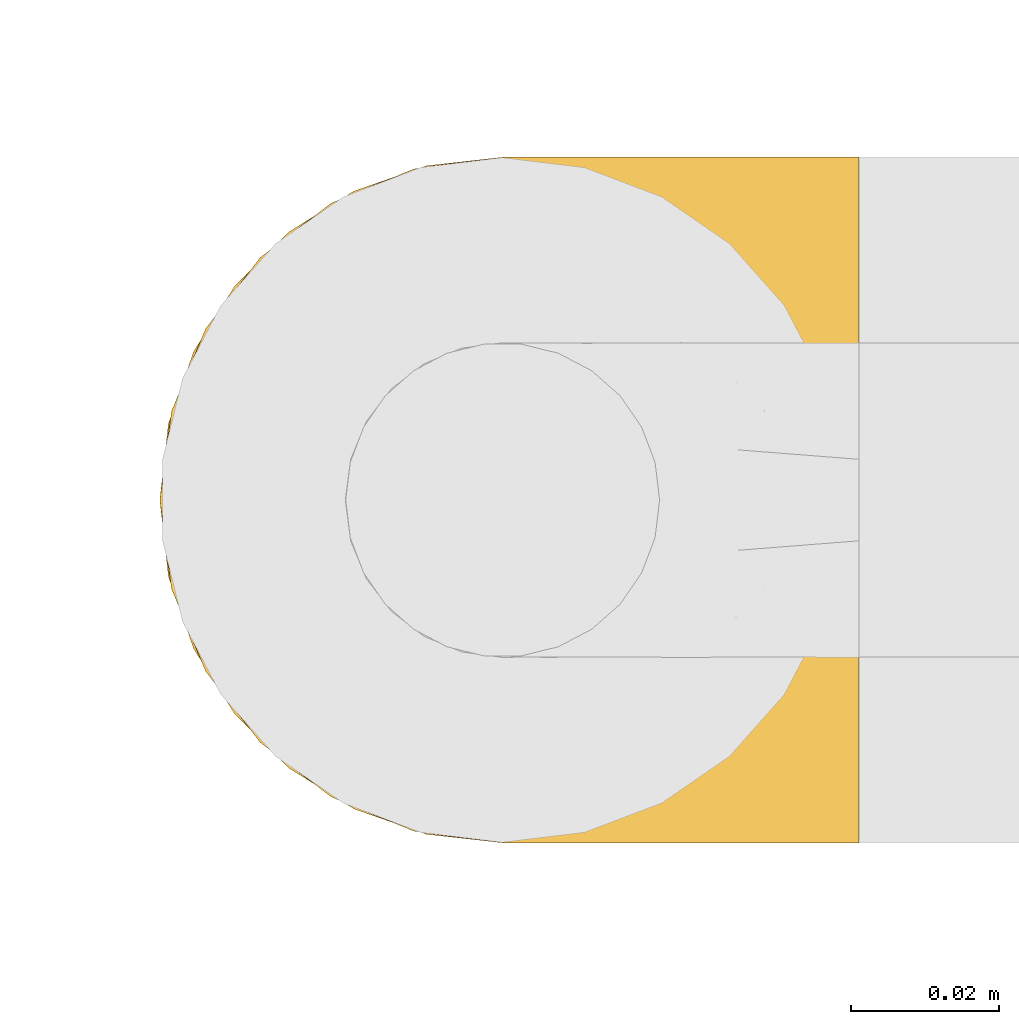
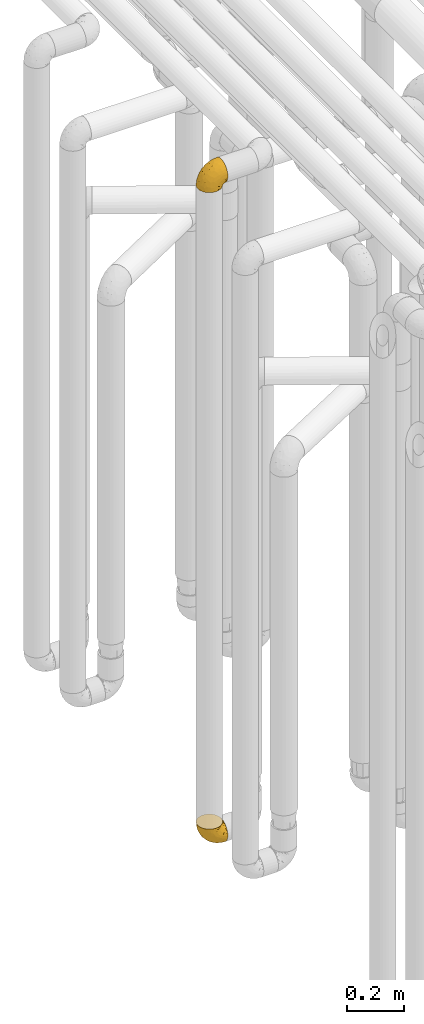
# One storey, part 163 of 827: 2 coverings.
"""IFC2X3 building model written with IfcOpenShell, lengths in millimetres."""

from ifc_helpers import new_model, entity, si_unit, converted_unit, derived_unit, direction, frame, origin, place, context, subcontext, project, spatial, faceted_brep, element, save


model = new_model("IFC2X3")

# Units and contexts
model_context = context("Model", 3, precision=0.01, world=origin(), true_north=direction((6.12303176911189e-17, 1.0)))
body_context = subcontext(model_context, "Body", "Model", "MODEL_VIEW")
ifc_project = project(units=[si_unit("LENGTHUNIT", "METRE", prefix="MILLI"), si_unit("AREAUNIT", "SQUARE_METRE"), si_unit("VOLUMEUNIT", "CUBIC_METRE"), converted_unit("PLANEANGLEUNIT", "DEGREE", entity("IfcRatioMeasure", 0.0174532925199433), si_unit("PLANEANGLEUNIT", "RADIAN"), dimensions=[0, 0, 0, 0, 0, 0, 0]), si_unit("MASSUNIT", "GRAM", prefix="KILO"), derived_unit("MASSDENSITYUNIT", [(si_unit("MASSUNIT", "GRAM", prefix="KILO"), 1), (si_unit("LENGTHUNIT", "METRE"), -3)]), derived_unit("MOMENTOFINERTIAUNIT", [(si_unit("LENGTHUNIT", "METRE"), 4)]), si_unit("TIMEUNIT", "SECOND"), si_unit("FREQUENCYUNIT", "HERTZ"), si_unit("THERMODYNAMICTEMPERATUREUNIT", "DEGREE_CELSIUS"), derived_unit("THERMALTRANSMITTANCEUNIT", [(si_unit("MASSUNIT", "GRAM", prefix="KILO"), 1), (si_unit("THERMODYNAMICTEMPERATUREUNIT", "KELVIN"), -1), (si_unit("TIMEUNIT", "SECOND"), -3)]), derived_unit("VOLUMETRICFLOWRATEUNIT", [(si_unit("LENGTHUNIT", "METRE"), 3), (si_unit("TIMEUNIT", "SECOND"), -1)]), derived_unit("MASSFLOWRATEUNIT", [(si_unit("MASSUNIT", "GRAM", prefix="KILO"), 1), (si_unit("TIMEUNIT", "SECOND"), -1)]), derived_unit("ROTATIONALFREQUENCYUNIT", [(si_unit("TIMEUNIT", "SECOND"), -1)]), si_unit("ELECTRICCURRENTUNIT", "AMPERE"), si_unit("ELECTRICVOLTAGEUNIT", "VOLT"), si_unit("POWERUNIT", "WATT"), si_unit("FORCEUNIT", "NEWTON", prefix="KILO"), si_unit("ILLUMINANCEUNIT", "LUX"), si_unit("LUMINOUSFLUXUNIT", "LUMEN"), si_unit("LUMINOUSINTENSITYUNIT", "CANDELA"), derived_unit("USERDEFINED", [(si_unit("MASSUNIT", "GRAM", prefix="KILO"), -1), (si_unit("LENGTHUNIT", "METRE"), -2), (si_unit("TIMEUNIT", "SECOND"), 3), (si_unit("LUMINOUSFLUXUNIT", "LUMEN"), 1)]), derived_unit("LINEARVELOCITYUNIT", [(si_unit("LENGTHUNIT", "METRE"), 1), (si_unit("TIMEUNIT", "SECOND"), -1)]), si_unit("PRESSUREUNIT", "PASCAL"), derived_unit("USERDEFINED", [(si_unit("LENGTHUNIT", "METRE"), -2), (si_unit("MASSUNIT", "GRAM", prefix="KILO"), 1), (si_unit("TIMEUNIT", "SECOND"), -2)]), derived_unit("LINEARFORCEUNIT", [(si_unit("MASSUNIT", "GRAM", prefix="KILO"), 1), (si_unit("LENGTHUNIT", "METRE"), 1), (si_unit("TIMEUNIT", "SECOND"), -2), (si_unit("LENGTHUNIT", "METRE"), -1)]), derived_unit("PLANARFORCEUNIT", [(si_unit("MASSUNIT", "GRAM", prefix="KILO"), 1), (si_unit("LENGTHUNIT", "METRE"), 1), (si_unit("TIMEUNIT", "SECOND"), -2), (si_unit("LENGTHUNIT", "METRE"), -2)])], contexts=[model_context])

# Site, building, storey
site_placement = place(None, origin())
site = spatial("IfcSite", under=ifc_project, at=site_placement, CompositionType="ELEMENT")
building_placement = place(site_placement, origin())
building = spatial("IfcBuilding", under=site, at=building_placement, CompositionType="ELEMENT")
storey_placement = place(building_placement, frame((0.0, 0.0, 28200.0)))
storey = spatial("IfcBuildingStorey", under=building, at=storey_placement, Name="08", CompositionType="ELEMENT", Elevation=28200.0)

# Coverings
covering_1_placement = place(storey_placement, frame((35072.24, 11758.41, 352.2)))
element("IfcCovering", 1, at=covering_1_placement, inside=storey, Name=":ADSK_", ObjectType=":ADSK_", PredefinedType="INSULATION", context=body_context, shape_type="Brep", body=[
    faceted_brep([(18.98, 83.91, 95.8), (11.67, 76.59, 95.8), (6.17, 67.83, 95.8), (2.75, 58.07, 95.8), (1.6, 47.8, 95.8), (2.75, 37.51, 95.8), (6.17, 27.74, 95.8), (11.68, 18.98, 95.8), (19.0, 11.67, 95.8), (27.76, 6.17, 95.8), (37.52, 2.75, 95.8), (47.8, 1.6, 95.8), (51.94, 2.06, 95.8), (55.01, 2.41, 95.8), (58.08, 2.75, 95.8), (62.96, 4.46, 95.8), (67.85, 6.17, 95.8), (72.23, 8.93, 95.8), (76.61, 11.68, 95.8), (80.26, 15.34, 95.8), (83.92, 19.0, 95.8), (89.42, 27.76, 95.8), (91.13, 32.64, 95.8), (92.84, 37.52, 95.8), (94.0, 47.8, 95.8), (92.84, 58.08, 95.8), (91.13, 62.96, 95.8), (89.42, 67.85, 95.8), (83.91, 76.61, 95.8), (80.25, 80.26, 95.8), (76.59, 83.92, 95.8), (72.21, 86.67, 95.8), (67.83, 89.42, 95.8), (62.95, 91.13, 95.8), (58.07, 92.84, 95.8), (55.0, 93.18, 95.8), (51.94, 93.53, 95.8), (47.8, 94.0, 95.8), (37.51, 92.84, 95.8), (27.74, 89.42, 95.8), (95.8, 47.8, 94.0), (95.8, 35.84, 92.42), (95.8, 24.7, 87.81), (95.8, 19.91, 84.13), (95.8, 15.13, 80.46), (95.8, 11.46, 75.68), (95.8, 7.78, 70.9), (95.8, 5.48, 65.32), (95.8, 3.17, 59.75), (95.8, 2.69, 56.14), (95.8, 2.42, 54.06), (95.8, 2.14, 51.97), (95.8, 1.6, 47.8), (95.8, 3.17, 35.84), (95.8, 7.78, 24.7), (95.8, 15.13, 15.13), (95.8, 24.7, 7.78), (95.8, 35.84, 3.17), (95.8, 47.8, 1.6), (95.8, 59.75, 3.17), (95.8, 70.9, 7.78), (95.8, 80.46, 15.13), (95.8, 87.81, 24.7), (95.8, 92.42, 35.84), (95.8, 94.0, 47.8), (95.8, 93.45, 51.97), (95.8, 92.9, 56.14), (95.8, 92.42, 59.75), (95.8, 90.11, 65.32), (95.8, 87.81, 70.9), (95.8, 84.13, 75.68), (95.8, 80.46, 80.46), (95.8, 75.68, 84.13), (95.8, 70.9, 87.81), (95.8, 59.75, 92.42), (60.58, 71.98, 15.84), (74.11, 63.6, 6.99), (51.59, 59.72, 14.39), (66.69, 47.8, 6.21), (76.19, 55.16, 4.26), (84.43, 47.8, 3.39), (31.2, 63.76, 31.2), (42.88, 72.22, 26.47), (79.41, 74.18, 11.44), (60.7, 92.52, 47.66), (61.85, 94.0, 61.85), (65.75, 94.0, 59.25), (69.64, 94.0, 56.65), (73.53, 94.0, 54.05), (77.43, 94.0, 51.45), (74.59, 82.14, 19.8), (54.72, 80.34, 26.22), (64.18, 87.52, 31.58), (37.94, 79.59, 38.36), (25.89, 78.25, 51.54), (34.73, 85.01, 51.6), (42.89, 90.25, 55.97), (49.83, 93.2, 62.88), (48.58, 87.23, 41.35), (22.41, 85.55, 82.24), (78.69, 93.0, 40.88), (81.64, 89.31, 29.0), (6.22, 61.31, 74.06), (12.11, 56.86, 54.53), (14.81, 68.34, 57.98), (21.61, 65.71, 43.81), (22.41, 56.99, 38.22), (30.12, 72.15, 38.33), (10.01, 70.34, 74.76), (15.36, 78.36, 76.85), (3.39, 47.8, 84.43), (19.59, 47.8, 40.43), (30.01, 47.8, 30.01), (41.19, 93.06, 78.67), (48.54, 94.0, 92.06), (49.28, 94.0, 88.32), (49.82, 94.0, 85.6), (50.37, 94.0, 82.88), (50.91, 94.0, 80.15), (51.45, 94.0, 77.43), (31.61, 89.88, 76.36), (80.15, 94.0, 50.91), (82.88, 94.0, 50.37), (85.6, 94.0, 49.82), (88.32, 94.0, 49.28), (90.19, 94.0, 48.91), (92.06, 94.0, 48.54), (6.21, 47.8, 66.69), (54.05, 94.0, 73.53), (56.65, 94.0, 69.64), (59.25, 94.0, 65.75), (24.66, 83.7, 66.13), (40.43, 47.8, 19.59), (35.17, 55.9, 24.64), (12.9, 47.8, 53.56), (53.56, 47.8, 12.9), (85.34, 81.75, 82.81), (78.44, 86.43, 81.22), (84.37, 79.8, 86.57), (89.05, 69.84, 92.75), (82.76, 79.5, 89.68), (86.31, 88.08, 72.26), (83.73, 91.6, 64.73), (77.31, 92.93, 62.45), (87.78, 92.43, 60.63), (87.91, 93.24, 56.91), (81.29, 93.36, 58.14), (93.97, 57.25, 93.7), (70.76, 89.41, 83.4), (63.67, 92.89, 75.54), (62.62, 92.66, 79.46), (90.64, 79.58, 82.28), (84.08, 86.51, 76.25), (76.28, 86.29, 84.69), (77.45, 83.91, 90.18), (88.72, 90.94, 65.12), (71.28, 91.94, 71.71), (68.09, 91.98, 75.21), (91.07, 82.79, 78.6), (57.47, 93.16, 87.27), (70.34, 88.76, 87.92), (91.35, 73.94, 86.94), (62.99, 91.89, 86.1), (94.52, 47.8, 94.52), (76.47, 92.22, 66.23), (69.96, 88.56, 91.08), (89.86, 87.72, 71.77), (78.94, 88.33, 76.21), (73.51, 92.18, 68.59), (89.62, 71.78, 89.94), (84.09, 9.09, 76.25), (86.3, 7.51, 72.26), (91.06, 12.8, 78.6), (88.32, 1.6, 49.28), (92.06, 1.6, 48.54), (82.88, 1.6, 50.37), (85.6, 1.6, 49.82), (93.97, 38.35, 93.7), (89.63, 23.84, 89.95), (50.37, 1.6, 82.88), (49.82, 1.6, 85.6), (48.54, 1.6, 92.06), (49.28, 1.6, 88.32), (82.77, 16.1, 89.68), (70.36, 6.84, 87.92), (77.31, 2.66, 62.45), (76.47, 3.37, 66.24), (69.64, 1.6, 56.65), (65.75, 1.6, 59.25), (87.78, 3.16, 60.63), (87.91, 2.35, 56.91), (89.06, 25.77, 92.76), (90.65, 16.02, 82.28), (85.35, 13.85, 82.81), (73.53, 1.6, 54.05), (77.43, 1.6, 51.45), (81.29, 2.23, 58.14), (77.46, 11.69, 90.18), (76.29, 9.31, 84.7), (57.47, 2.43, 87.25), (63.71, 2.71, 75.58), (68.11, 3.61, 75.2), (70.77, 6.18, 83.39), (71.31, 3.66, 71.7), (78.46, 9.17, 81.22), (69.52, 6.77, 90.73), (62.64, 2.93, 79.47), (91.35, 21.66, 86.94), (59.25, 1.6, 65.75), (84.6, 16.09, 86.75), (62.98, 3.7, 86.08), (51.45, 1.6, 77.43), (54.05, 1.6, 73.53), (56.65, 1.6, 69.64), (83.73, 3.99, 64.73), (80.15, 1.6, 50.91), (88.72, 4.65, 65.12), (61.85, 1.6, 61.85), (73.56, 3.43, 68.62), (78.96, 7.27, 76.22), (91.36, 9.46, 74.03), (50.91, 1.6, 80.15), (62.87, 2.4, 49.81), (76.19, 40.43, 4.26), (73.57, 13.57, 19.95), (56.07, 11.3, 30.61), (49.77, 18.65, 25.71), (44.73, 27.26, 22.43), (60.58, 23.61, 15.85), (47.64, 3.07, 60.69), (78.32, 2.69, 40.49), (51.59, 35.87, 14.39), (74.11, 31.99, 6.99), (76.04, 6.71, 29.56), (79.41, 21.41, 11.45), (14.82, 27.24, 57.98), (6.22, 34.26, 74.06), (12.12, 38.73, 54.52), (23.51, 26.97, 43.47), (31.2, 31.83, 31.2), (34.96, 23.4, 33.27), (33.86, 6.91, 64.26), (38.94, 3.4, 74.29), (30.23, 5.84, 80.41), (35.17, 39.69, 24.64), (15.85, 17.6, 73.62), (22.59, 10.38, 78.98), (21.56, 20.6, 53.69), (55.94, 5.36, 42.86), (20.67, 35.73, 41.67), (9.19, 24.84, 79.66), (25.79, 13.87, 58.41), (41.16, 9.06, 47.11), (37.95, 15.99, 38.37)], [[[0, 1, 2, 3, 4, 5, 6, 7, 8, 9, 10, 11, 12, 13, 14, 15, 16, 17, 18, 19, 20, 21, 22, 23, 24, 25, 26, 27, 28, 29, 30, 31, 32, 33, 34, 35, 36, 37, 38, 39]], [[40, 41, 42, 43, 44, 45, 46, 47, 48, 49, 50, 51, 52, 53, 54, 55, 56, 57, 58, 59, 60, 61, 62, 63, 64, 65, 66, 67, 68, 69, 70, 71, 72, 73, 74]], [[75, 76, 77]], [[78, 79, 80]], [[77, 81, 82]], [[76, 75, 83]], [[84, 85, 86, 87, 88, 89]], [[90, 91, 92]], [[76, 60, 59]], [[93, 94, 95]], [[90, 62, 61]], [[83, 61, 60]], [[96, 97, 84]], [[98, 93, 95]], [[0, 39, 99]], [[100, 84, 89]], [[62, 101, 63]], [[2, 102, 3]], [[92, 84, 100]], [[103, 102, 104]], [[103, 105, 106]], [[93, 107, 94]], [[1, 108, 2]], [[92, 101, 90]], [[108, 1, 109]], [[102, 110, 3]], [[93, 82, 107]], [[102, 108, 104]], [[111, 106, 112]], [[109, 0, 99]], [[113, 37, 114, 115, 116, 117, 118, 119]], [[120, 38, 113]], [[100, 89, 121, 122, 123, 124, 125, 126, 64]], [[127, 102, 103]], [[97, 119, 128, 129, 130, 85]], [[99, 120, 131]], [[132, 133, 77]], [[59, 80, 79]], [[1, 0, 109]], [[98, 84, 92]], [[94, 109, 131]], [[120, 39, 38]], [[93, 91, 82]], [[104, 94, 105]], [[97, 113, 119]], [[95, 120, 96]], [[83, 90, 61]], [[91, 93, 98]], [[64, 63, 100]], [[100, 63, 101]], [[77, 76, 79]], [[133, 106, 81]], [[84, 97, 85]], [[113, 96, 120]], [[113, 97, 96]], [[37, 113, 38]], [[110, 102, 127]], [[110, 4, 3]], [[103, 111, 134, 127]], [[90, 75, 91]], [[82, 81, 107]], [[91, 75, 82]], [[77, 82, 75]], [[76, 83, 60]], [[90, 83, 75]], [[105, 107, 81]], [[94, 131, 95]], [[105, 94, 107]], [[109, 94, 104]], [[120, 95, 131]], [[98, 95, 96]], [[84, 98, 96]], [[98, 92, 91]], [[106, 105, 81]], [[103, 104, 105]], [[112, 106, 133]], [[103, 106, 111]], [[112, 133, 132]], [[81, 77, 133]], [[77, 78, 135, 132]], [[120, 99, 39]], [[109, 99, 131]], [[59, 58, 80]], [[59, 79, 76]], [[90, 101, 62]], [[100, 101, 92]], [[2, 108, 102]], [[109, 104, 108]], [[78, 77, 79]], [[136, 137, 138]], [[27, 139, 140]], [[141, 142, 143]], [[144, 145, 121]], [[146, 89, 88]], [[147, 139, 25]], [[148, 149, 150]], [[136, 151, 152]], [[147, 40, 74]], [[24, 147, 25]], [[140, 153, 154]], [[33, 116, 34]], [[73, 72, 151]], [[114, 37, 36, 35, 34, 116, 115]], [[146, 155, 144]], [[156, 85, 130]], [[157, 149, 148]], [[151, 158, 152]], [[117, 33, 159]], [[29, 154, 160]], [[161, 74, 73]], [[162, 128, 119]], [[66, 65, 64, 126, 125, 124, 123, 122, 67]], [[163, 147, 24]], [[27, 140, 28]], [[149, 129, 150]], [[139, 27, 26, 25]], [[68, 144, 69]], [[129, 128, 150]], [[164, 87, 86]], [[130, 129, 149]], [[122, 145, 67]], [[154, 153, 148]], [[162, 119, 159]], [[165, 30, 160]], [[150, 160, 148]], [[128, 162, 150]], [[30, 165, 31]], [[145, 144, 68]], [[89, 146, 144]], [[87, 164, 143]], [[166, 155, 142]], [[88, 87, 143]], [[162, 160, 150]], [[160, 30, 29]], [[154, 29, 28]], [[140, 154, 28]], [[160, 154, 148]], [[140, 137, 153]], [[157, 148, 153]], [[156, 130, 157]], [[153, 137, 157]], [[157, 137, 156]], [[167, 137, 136]], [[168, 85, 156]], [[152, 168, 167]], [[167, 168, 156]], [[164, 152, 141]], [[71, 158, 72]], [[152, 167, 136]], [[88, 142, 146]], [[144, 155, 69]], [[146, 142, 155]], [[70, 166, 71]], [[142, 141, 166]], [[70, 69, 155]], [[141, 158, 71]], [[161, 73, 151]], [[138, 137, 140]], [[161, 136, 169]], [[136, 161, 151]], [[74, 161, 169]], [[152, 158, 141]], [[151, 72, 158]], [[168, 152, 164]], [[137, 167, 156]], [[164, 86, 168]], [[85, 168, 86]], [[116, 33, 117]], [[130, 149, 157]], [[67, 145, 68]], [[121, 89, 144]], [[145, 122, 121]], [[40, 147, 163]], [[169, 147, 74]], [[159, 33, 32]], [[162, 159, 32]], [[159, 119, 118, 117]], [[139, 147, 169]], [[139, 169, 138]], [[162, 32, 31]], [[141, 143, 164]], [[88, 143, 142]], [[71, 166, 141]], [[155, 166, 70]], [[139, 138, 140]], [[169, 136, 138]], [[160, 162, 165]], [[162, 31, 165]], [[170, 171, 172]], [[173, 174, 52, 51, 50, 49, 48, 175, 176]], [[177, 178, 41]], [[179, 15, 180]], [[12, 11, 181, 182, 180, 14, 13]], [[183, 21, 20]], [[19, 18, 184]], [[185, 186, 187]], [[186, 188, 187]], [[43, 172, 44]], [[189, 190, 47]], [[23, 22, 21, 191]], [[170, 192, 193]], [[40, 163, 177]], [[194, 195, 196]], [[24, 23, 177]], [[197, 198, 183]], [[199, 15, 179]], [[47, 46, 189]], [[200, 201, 202]], [[201, 203, 204]], [[205, 206, 184]], [[207, 41, 178]], [[16, 15, 199]], [[14, 180, 15]], [[202, 201, 198]], [[208, 201, 200]], [[163, 24, 177]], [[48, 47, 190]], [[196, 195, 189]], [[197, 184, 202]], [[204, 193, 209]], [[210, 211, 212]], [[206, 212, 213]], [[205, 17, 210]], [[184, 206, 202]], [[210, 212, 206]], [[185, 194, 214]], [[189, 215, 190]], [[216, 45, 214]], [[186, 171, 170]], [[189, 216, 196]], [[197, 20, 19]], [[194, 185, 187]], [[197, 183, 20]], [[184, 197, 19]], [[197, 202, 198]], [[206, 200, 202]], [[204, 183, 198]], [[201, 208, 203]], [[203, 208, 217]], [[204, 198, 201]], [[217, 188, 218]], [[193, 219, 170]], [[171, 186, 185]], [[170, 218, 186]], [[170, 219, 218]], [[42, 207, 192]], [[171, 220, 172]], [[216, 189, 46]], [[214, 194, 196]], [[44, 220, 45]], [[214, 196, 216]], [[216, 46, 45]], [[214, 45, 220]], [[192, 43, 42]], [[204, 203, 219]], [[207, 193, 192]], [[209, 193, 178]], [[41, 207, 42]], [[193, 207, 178]], [[43, 192, 172]], [[170, 172, 192]], [[204, 219, 193]], [[219, 203, 218]], [[217, 218, 203]], [[188, 186, 218]], [[206, 213, 200]], [[208, 200, 213]], [[199, 210, 16]], [[215, 189, 195]], [[215, 175, 190]], [[175, 48, 190]], [[199, 179, 221, 211]], [[210, 199, 211]], [[23, 191, 177]], [[40, 177, 41]], [[178, 177, 191]], [[21, 183, 191]], [[209, 191, 183]], [[205, 18, 17]], [[17, 16, 210]], [[171, 185, 214]], [[172, 220, 44]], [[214, 220, 171]], [[191, 209, 178]], [[204, 209, 183]], [[206, 205, 210]], [[18, 205, 184]], [[222, 195, 194, 187, 188, 217]], [[57, 223, 80]], [[224, 225, 226]], [[226, 227, 228]], [[229, 217, 208, 213, 212, 211]], [[230, 52, 174, 173, 176, 175, 215, 195]], [[231, 232, 228]], [[231, 78, 223]], [[223, 57, 232]], [[224, 233, 225]], [[233, 54, 53]], [[234, 232, 56]], [[56, 55, 234]], [[234, 224, 228]], [[235, 236, 237]], [[224, 55, 54]], [[238, 239, 240]], [[52, 230, 53]], [[241, 242, 243]], [[227, 244, 231]], [[11, 10, 242]], [[236, 6, 5]], [[7, 245, 8]], [[8, 246, 9]], [[238, 247, 235]], [[222, 229, 248]], [[242, 211, 221, 179, 180, 182, 181, 11]], [[233, 53, 230]], [[111, 112, 249]], [[250, 6, 236]], [[246, 251, 241]], [[6, 250, 7]], [[127, 236, 110]], [[248, 229, 252]], [[246, 8, 245]], [[235, 245, 250]], [[236, 5, 110]], [[235, 249, 238]], [[237, 236, 127]], [[243, 9, 246]], [[252, 229, 241]], [[56, 232, 57]], [[222, 230, 195]], [[225, 248, 252]], [[248, 233, 230]], [[54, 233, 224]], [[231, 228, 227]], [[244, 132, 231]], [[248, 225, 233]], [[226, 225, 253]], [[235, 250, 236]], [[245, 7, 250]], [[251, 246, 245]], [[243, 246, 241]], [[247, 245, 235]], [[252, 251, 253]], [[229, 222, 217]], [[230, 222, 248]], [[5, 4, 110]], [[237, 127, 134, 111]], [[238, 249, 239]], [[224, 234, 55]], [[232, 234, 228]], [[242, 241, 229]], [[10, 9, 243]], [[211, 242, 229]], [[10, 243, 242]], [[80, 223, 78]], [[80, 58, 57]], [[231, 223, 232]], [[227, 240, 239]], [[224, 226, 228]], [[240, 226, 253]], [[227, 239, 244]], [[226, 240, 227]], [[251, 247, 253]], [[240, 253, 247]], [[249, 235, 237]], [[237, 111, 249]], [[112, 132, 244]], [[112, 244, 249]], [[78, 231, 132, 135]], [[249, 244, 239]], [[247, 238, 240]], [[245, 247, 251]], [[251, 252, 241]], [[225, 252, 253]]]),
])
covering_2_placement = place(storey_placement, frame((35072.24, 11758.41, 3150.4)))
element("IfcCovering", 2, at=covering_2_placement, inside=storey, Name=":ADSK_", ObjectType=":ADSK_", PredefinedType="INSULATION", context=body_context, shape_type="Brep", body=[
    faceted_brep([(95.8, 83.91, 78.41), (95.8, 76.59, 85.72), (95.8, 67.83, 91.22), (95.8, 58.07, 94.64), (95.8, 47.8, 95.8), (95.8, 37.51, 94.64), (95.8, 27.74, 91.22), (95.8, 18.98, 85.71), (95.8, 11.67, 78.39), (95.8, 6.17, 69.63), (95.8, 2.75, 59.87), (95.8, 1.6, 49.6), (95.8, 2.06, 45.45), (95.8, 2.41, 42.38), (95.8, 2.75, 39.31), (95.8, 4.46, 34.43), (95.8, 6.17, 29.54), (95.8, 8.93, 25.16), (95.8, 11.68, 20.78), (95.8, 15.34, 17.13), (95.8, 19.0, 13.47), (95.8, 27.76, 7.97), (95.8, 32.64, 6.26), (95.8, 37.52, 4.55), (95.8, 47.8, 3.4), (95.8, 58.08, 4.55), (95.8, 62.96, 6.26), (95.8, 67.85, 7.97), (95.8, 76.61, 13.48), (95.8, 80.26, 17.14), (95.8, 83.92, 20.8), (95.8, 86.67, 25.18), (95.8, 89.42, 29.56), (95.8, 91.13, 34.44), (95.8, 92.84, 39.32), (95.8, 93.18, 42.39), (95.8, 93.53, 45.45), (95.8, 94.0, 49.6), (95.8, 92.84, 59.88), (95.8, 89.42, 69.65), (94.0, 47.8, 1.6), (92.42, 35.84, 1.6), (87.81, 24.7, 1.6), (84.13, 19.91, 1.6), (80.46, 15.13, 1.6), (75.68, 11.46, 1.6), (70.9, 7.78, 1.6), (65.32, 5.48, 1.6), (59.75, 3.17, 1.6), (56.14, 2.69, 1.6), (54.06, 2.42, 1.6), (51.97, 2.14, 1.6), (47.8, 1.6, 1.6), (35.84, 3.17, 1.6), (24.7, 7.78, 1.6), (15.13, 15.13, 1.6), (7.78, 24.7, 1.6), (3.17, 35.84, 1.6), (1.6, 47.8, 1.6), (3.17, 59.75, 1.6), (7.78, 70.9, 1.6), (15.13, 80.46, 1.6), (24.7, 87.81, 1.6), (35.84, 92.42, 1.6), (47.8, 94.0, 1.6), (51.97, 93.45, 1.6), (56.14, 92.9, 1.6), (59.75, 92.42, 1.6), (65.32, 90.11, 1.6), (70.9, 87.81, 1.6), (75.68, 84.13, 1.6), (80.46, 80.46, 1.6), (84.13, 75.68, 1.6), (87.81, 70.9, 1.6), (92.42, 59.75, 1.6), (15.84, 71.98, 36.81), (6.99, 63.6, 23.28), (14.39, 59.72, 45.8), (6.21, 47.8, 30.7), (4.26, 55.16, 21.2), (3.39, 47.8, 12.96), (31.2, 63.76, 66.19), (26.47, 72.22, 54.51), (11.44, 74.18, 17.98), (47.66, 92.52, 36.69), (61.85, 94.0, 35.54), (59.25, 94.0, 31.64), (56.65, 94.0, 27.75), (54.05, 94.0, 23.86), (51.45, 94.0, 19.96), (19.8, 82.14, 22.8), (26.22, 80.34, 42.67), (31.58, 87.52, 33.21), (38.36, 79.59, 59.45), (51.54, 78.25, 71.5), (51.6, 85.01, 62.66), (55.97, 90.25, 54.5), (62.88, 93.2, 47.57), (41.35, 87.23, 48.81), (82.24, 85.55, 74.98), (40.88, 93.0, 18.7), (29.0, 89.31, 15.75), (74.06, 61.31, 91.17), (54.53, 56.86, 85.28), (57.98, 68.34, 82.58), (43.81, 65.71, 75.78), (38.22, 56.99, 74.98), (38.33, 72.15, 67.27), (74.76, 70.34, 87.38), (76.85, 78.36, 82.04), (84.43, 47.8, 94.0), (40.43, 47.8, 77.8), (30.01, 47.8, 67.38), (78.67, 93.06, 56.2), (92.06, 94.0, 48.85), (88.32, 94.0, 48.11), (85.6, 94.0, 47.57), (82.88, 94.0, 47.03), (80.15, 94.0, 46.48), (77.43, 94.0, 45.94), (76.36, 89.88, 65.78), (50.91, 94.0, 17.24), (50.37, 94.0, 14.51), (49.82, 94.0, 11.79), (49.28, 94.0, 9.07), (48.91, 94.0, 7.2), (48.54, 94.0, 5.33), (66.69, 47.8, 91.18), (73.53, 94.0, 43.34), (69.64, 94.0, 40.74), (65.75, 94.0, 38.14), (66.13, 83.7, 72.73), (19.59, 47.8, 56.96), (24.64, 55.9, 62.23), (53.56, 47.8, 84.49), (12.9, 47.8, 43.83), (82.81, 81.75, 12.05), (81.22, 86.43, 18.95), (86.57, 79.8, 13.02), (92.75, 69.84, 8.34), (89.68, 79.5, 14.63), (72.26, 88.08, 11.09), (64.73, 91.6, 13.66), (62.45, 92.93, 20.08), (60.63, 92.43, 9.61), (56.91, 93.24, 9.48), (58.14, 93.36, 16.1), (93.7, 57.25, 3.42), (83.4, 89.41, 26.63), (75.54, 92.89, 33.72), (79.46, 92.66, 34.77), (82.28, 79.58, 6.75), (76.25, 86.51, 13.31), (84.69, 86.29, 21.11), (90.18, 83.91, 19.94), (86.94, 73.94, 6.04), (65.12, 90.94, 8.67), (71.71, 91.94, 26.11), (75.21, 91.98, 29.3), (78.6, 82.79, 6.32), (87.27, 93.16, 39.92), (87.92, 88.76, 27.05), (86.1, 91.89, 34.4), (94.52, 47.8, 2.87), (66.23, 92.22, 20.92), (91.08, 88.56, 27.43), (71.77, 87.72, 7.54), (76.21, 88.33, 18.45), (68.59, 92.18, 23.88), (89.94, 71.78, 7.77), (76.22, 7.27, 18.43), (81.22, 9.17, 18.93), (71.7, 3.66, 26.08), (49.28, 1.6, 9.07), (48.54, 1.6, 5.33), (50.37, 1.6, 14.51), (49.82, 1.6, 11.79), (93.7, 38.35, 3.42), (89.95, 23.84, 7.76), (82.88, 1.6, 47.03), (85.6, 1.6, 47.57), (92.06, 1.6, 48.85), (88.32, 1.6, 48.11), (89.68, 16.1, 14.62), (87.92, 6.84, 27.03), (62.45, 2.66, 20.08), (66.24, 3.37, 20.92), (56.65, 1.6, 27.75), (59.25, 1.6, 31.64), (78.6, 12.8, 6.33), (60.63, 3.16, 9.61), (56.91, 2.35, 9.48), (92.76, 25.77, 8.33), (76.25, 9.09, 13.3), (82.28, 16.02, 6.74), (82.81, 13.85, 12.04), (54.05, 1.6, 23.86), (51.45, 1.6, 19.96), (58.14, 2.23, 16.1), (90.18, 11.69, 19.93), (84.7, 9.31, 21.1), (87.25, 2.43, 39.92), (75.58, 2.71, 33.68), (75.2, 3.61, 29.28), (83.39, 6.18, 26.62), (90.73, 6.77, 27.87), (79.47, 2.93, 34.75), (86.94, 21.66, 6.04), (65.75, 1.6, 38.14), (86.75, 16.09, 12.79), (86.08, 3.7, 34.41), (77.43, 1.6, 45.94), (73.53, 1.6, 43.34), (69.64, 1.6, 40.74), (64.73, 3.99, 13.66), (50.91, 1.6, 17.24), (65.12, 4.65, 8.67), (72.26, 7.51, 11.09), (61.85, 1.6, 35.54), (68.62, 3.43, 23.83), (74.03, 9.46, 6.03), (80.15, 1.6, 46.48), (49.81, 2.4, 34.52), (4.26, 40.43, 21.2), (19.95, 13.57, 23.82), (30.61, 11.3, 41.32), (25.71, 18.65, 47.62), (22.43, 27.26, 52.66), (15.85, 23.61, 36.81), (60.69, 3.07, 49.75), (40.49, 2.69, 19.07), (14.39, 35.87, 45.8), (6.99, 31.99, 23.28), (29.56, 6.71, 21.35), (11.45, 21.41, 17.98), (57.98, 27.24, 82.57), (74.06, 34.26, 91.17), (54.52, 38.73, 85.27), (43.47, 26.97, 73.89), (31.2, 31.83, 66.19), (33.27, 23.4, 62.43), (64.26, 6.91, 63.53), (74.29, 3.4, 58.45), (80.41, 5.84, 67.16), (24.64, 39.69, 62.22), (73.62, 17.6, 81.54), (78.98, 10.38, 74.8), (53.69, 20.6, 75.83), (42.86, 5.36, 41.45), (41.67, 35.73, 76.72), (79.66, 24.84, 88.2), (58.41, 13.87, 71.6), (47.11, 9.06, 56.23), (38.37, 15.99, 59.44)], [[[0, 1, 2, 3, 4, 5, 6, 7, 8, 9, 10, 11, 12, 13, 14, 15, 16, 17, 18, 19, 20, 21, 22, 23, 24, 25, 26, 27, 28, 29, 30, 31, 32, 33, 34, 35, 36, 37, 38, 39]], [[40, 41, 42, 43, 44, 45, 46, 47, 48, 49, 50, 51, 52, 53, 54, 55, 56, 57, 58, 59, 60, 61, 62, 63, 64, 65, 66, 67, 68, 69, 70, 71, 72, 73, 74]], [[75, 76, 77]], [[78, 79, 80]], [[77, 81, 82]], [[76, 75, 83]], [[84, 85, 86, 87, 88, 89]], [[90, 91, 92]], [[76, 60, 59]], [[93, 94, 95]], [[90, 62, 61]], [[83, 61, 60]], [[96, 97, 84]], [[98, 93, 95]], [[0, 39, 99]], [[100, 84, 89]], [[62, 101, 63]], [[2, 102, 3]], [[92, 84, 100]], [[103, 102, 104]], [[103, 105, 106]], [[93, 107, 94]], [[1, 108, 2]], [[92, 101, 90]], [[108, 1, 109]], [[102, 110, 3]], [[93, 82, 107]], [[102, 108, 104]], [[111, 106, 112]], [[109, 0, 99]], [[113, 37, 114, 115, 116, 117, 118, 119]], [[120, 38, 113]], [[100, 89, 121, 122, 123, 124, 125, 126, 64]], [[127, 102, 103]], [[97, 119, 128, 129, 130, 85]], [[99, 120, 131]], [[132, 133, 77]], [[59, 80, 79]], [[1, 0, 109]], [[98, 84, 92]], [[94, 109, 131]], [[120, 39, 38]], [[93, 91, 82]], [[104, 94, 105]], [[97, 113, 119]], [[95, 120, 96]], [[83, 90, 61]], [[91, 93, 98]], [[64, 63, 100]], [[100, 63, 101]], [[77, 76, 79]], [[133, 106, 81]], [[84, 97, 85]], [[113, 96, 120]], [[113, 97, 96]], [[37, 113, 38]], [[110, 102, 127]], [[110, 4, 3]], [[103, 111, 134, 127]], [[90, 75, 91]], [[82, 81, 107]], [[91, 75, 82]], [[77, 82, 75]], [[76, 83, 60]], [[90, 83, 75]], [[105, 107, 81]], [[94, 131, 95]], [[105, 94, 107]], [[109, 94, 104]], [[120, 95, 131]], [[98, 95, 96]], [[84, 98, 96]], [[98, 92, 91]], [[106, 105, 81]], [[103, 104, 105]], [[112, 106, 133]], [[103, 106, 111]], [[112, 133, 132]], [[81, 77, 133]], [[77, 78, 135, 132]], [[120, 99, 39]], [[109, 99, 131]], [[59, 58, 80]], [[59, 79, 76]], [[90, 101, 62]], [[100, 101, 92]], [[2, 108, 102]], [[109, 104, 108]], [[78, 77, 79]], [[136, 137, 138]], [[27, 139, 140]], [[141, 142, 143]], [[144, 145, 121]], [[146, 89, 88]], [[147, 139, 25]], [[148, 149, 150]], [[136, 151, 152]], [[147, 40, 74]], [[24, 147, 25]], [[140, 153, 154]], [[33, 116, 34]], [[73, 151, 155]], [[114, 37, 36, 35, 34, 116, 115]], [[146, 156, 144]], [[157, 85, 130]], [[158, 149, 148]], [[151, 159, 152]], [[117, 33, 160]], [[29, 154, 161]], [[155, 74, 73]], [[162, 128, 119]], [[66, 65, 64, 126, 125, 124, 123, 122, 67]], [[163, 147, 24]], [[27, 140, 28]], [[149, 129, 150]], [[139, 27, 26, 25]], [[68, 144, 69]], [[129, 128, 150]], [[164, 87, 86]], [[130, 129, 149]], [[122, 145, 67]], [[154, 153, 148]], [[162, 119, 160]], [[165, 30, 161]], [[150, 161, 148]], [[128, 162, 150]], [[30, 165, 31]], [[145, 144, 68]], [[89, 146, 144]], [[87, 164, 143]], [[166, 156, 142]], [[88, 87, 143]], [[162, 161, 150]], [[161, 30, 29]], [[154, 29, 28]], [[140, 154, 28]], [[161, 154, 148]], [[140, 137, 153]], [[158, 148, 153]], [[157, 130, 158]], [[153, 137, 158]], [[158, 137, 157]], [[167, 137, 136]], [[168, 85, 157]], [[152, 168, 167]], [[167, 168, 157]], [[164, 152, 141]], [[151, 73, 72]], [[159, 72, 71]], [[88, 142, 146]], [[144, 156, 69]], [[146, 142, 156]], [[70, 166, 71]], [[142, 141, 166]], [[70, 69, 156]], [[141, 159, 71]], [[167, 136, 152]], [[138, 137, 140]], [[155, 136, 169]], [[136, 155, 151]], [[74, 155, 169]], [[152, 159, 141]], [[151, 72, 159]], [[168, 152, 164]], [[137, 167, 157]], [[164, 86, 168]], [[85, 168, 86]], [[116, 33, 117]], [[130, 149, 158]], [[67, 145, 68]], [[121, 89, 144]], [[145, 122, 121]], [[40, 147, 163]], [[169, 147, 74]], [[160, 33, 32]], [[162, 160, 32]], [[160, 119, 118, 117]], [[139, 147, 169]], [[139, 169, 138]], [[162, 32, 31]], [[141, 143, 164]], [[88, 143, 142]], [[71, 166, 141]], [[156, 166, 70]], [[139, 138, 140]], [[169, 136, 138]], [[161, 162, 165]], [[162, 31, 165]], [[170, 171, 172]], [[173, 174, 52, 51, 50, 49, 48, 175, 176]], [[177, 178, 41]], [[179, 15, 180]], [[12, 11, 181, 182, 180, 14, 13]], [[183, 21, 20]], [[19, 18, 184]], [[185, 186, 187]], [[186, 188, 187]], [[43, 189, 44]], [[190, 191, 47]], [[23, 22, 21, 192]], [[193, 194, 195]], [[40, 163, 177]], [[196, 197, 198]], [[24, 23, 177]], [[199, 200, 183]], [[201, 15, 179]], [[47, 46, 190]], [[202, 203, 204]], [[203, 172, 171]], [[205, 206, 184]], [[207, 41, 178]], [[16, 15, 201]], [[14, 180, 15]], [[204, 203, 200]], [[208, 203, 202]], [[163, 24, 177]], [[48, 47, 191]], [[198, 197, 190]], [[199, 184, 204]], [[171, 195, 209]], [[210, 211, 212]], [[206, 212, 213]], [[205, 17, 210]], [[184, 206, 204]], [[210, 212, 206]], [[185, 196, 214]], [[190, 215, 191]], [[216, 45, 214]], [[186, 217, 193]], [[190, 216, 198]], [[199, 20, 19]], [[196, 185, 187]], [[199, 183, 20]], [[184, 199, 19]], [[199, 204, 200]], [[206, 202, 204]], [[171, 183, 200]], [[203, 208, 172]], [[172, 208, 218]], [[171, 200, 203]], [[218, 188, 219]], [[195, 170, 193]], [[217, 186, 185]], [[193, 219, 186]], [[193, 170, 219]], [[207, 194, 42]], [[217, 220, 189]], [[216, 190, 46]], [[214, 196, 198]], [[44, 220, 45]], [[214, 198, 216]], [[216, 46, 45]], [[214, 45, 220]], [[42, 194, 43]], [[189, 193, 217]], [[207, 195, 194]], [[209, 195, 178]], [[41, 207, 42]], [[195, 207, 178]], [[43, 194, 189]], [[193, 189, 194]], [[171, 170, 195]], [[170, 172, 219]], [[218, 219, 172]], [[188, 186, 219]], [[206, 213, 202]], [[208, 202, 213]], [[201, 210, 16]], [[215, 190, 197]], [[215, 175, 191]], [[175, 48, 191]], [[201, 179, 221, 211]], [[210, 201, 211]], [[23, 192, 177]], [[40, 177, 41]], [[183, 209, 192]], [[183, 192, 21]], [[192, 178, 177]], [[205, 18, 17]], [[17, 16, 210]], [[217, 185, 214]], [[189, 220, 44]], [[214, 220, 217]], [[192, 209, 178]], [[171, 209, 183]], [[206, 205, 210]], [[18, 205, 184]], [[222, 197, 196, 187, 188, 218]], [[57, 223, 80]], [[224, 225, 226]], [[226, 227, 228]], [[229, 218, 208, 213, 212, 211]], [[230, 52, 174, 173, 176, 175, 215, 197]], [[231, 232, 228]], [[231, 78, 223]], [[223, 57, 232]], [[224, 233, 225]], [[233, 54, 53]], [[234, 232, 56]], [[56, 55, 234]], [[234, 224, 228]], [[235, 236, 237]], [[224, 55, 54]], [[238, 239, 240]], [[52, 230, 53]], [[241, 242, 243]], [[231, 227, 244]], [[11, 10, 242]], [[236, 6, 5]], [[7, 245, 8]], [[8, 246, 9]], [[238, 247, 235]], [[222, 229, 248]], [[242, 211, 221, 179, 180, 182, 181, 11]], [[233, 53, 230]], [[111, 112, 249]], [[250, 6, 236]], [[246, 251, 241]], [[6, 250, 7]], [[127, 236, 110]], [[248, 229, 252]], [[246, 8, 245]], [[235, 245, 250]], [[236, 5, 110]], [[235, 249, 238]], [[237, 236, 127]], [[243, 9, 246]], [[252, 229, 241]], [[56, 232, 57]], [[222, 230, 197]], [[225, 248, 252]], [[248, 233, 230]], [[54, 233, 224]], [[231, 228, 227]], [[244, 132, 231]], [[248, 225, 233]], [[226, 225, 253]], [[235, 250, 236]], [[245, 7, 250]], [[251, 246, 245]], [[243, 246, 241]], [[247, 245, 235]], [[252, 251, 253]], [[229, 222, 218]], [[230, 222, 248]], [[5, 4, 110]], [[237, 127, 134, 111]], [[238, 249, 239]], [[224, 234, 55]], [[232, 234, 228]], [[242, 241, 229]], [[10, 9, 243]], [[211, 242, 229]], [[10, 243, 242]], [[80, 223, 78]], [[80, 58, 57]], [[231, 223, 232]], [[227, 240, 239]], [[224, 226, 228]], [[240, 226, 253]], [[227, 239, 244]], [[226, 240, 227]], [[251, 247, 253]], [[240, 253, 247]], [[249, 235, 237]], [[237, 111, 249]], [[244, 239, 249]], [[112, 244, 249]], [[135, 78, 231, 132]], [[112, 132, 244]], [[247, 238, 240]], [[245, 247, 251]], [[251, 252, 241]], [[225, 252, 253]]]),
])

save(model, "model.ifc")
